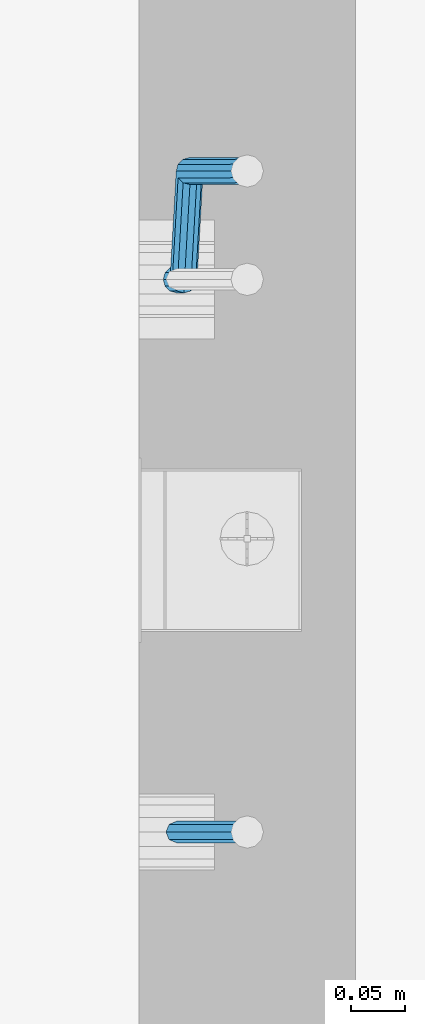
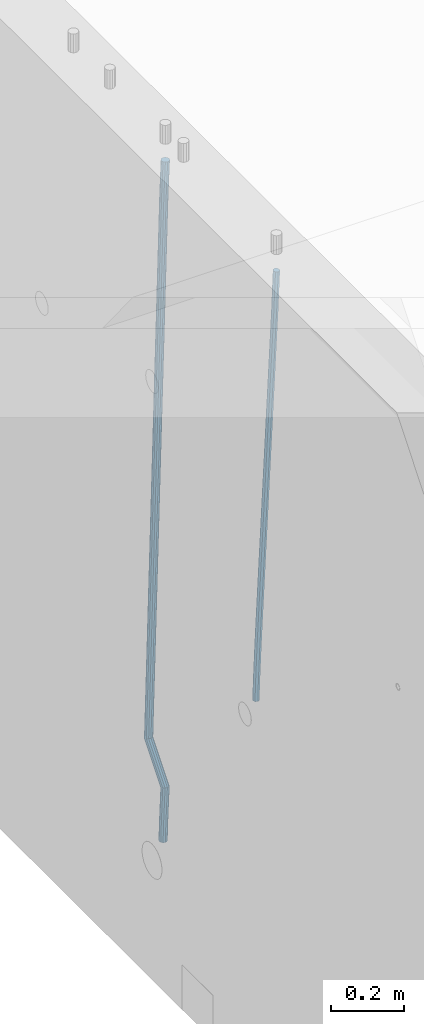
# One storey, part 103 of 349: 2 beams, 1 element without a shape of its own.
"""IFC2X3 building model written with IfcOpenShell, lengths in millimetres."""

from ifc_helpers import new_model, si_unit, frame, origin_with_axes, place, context, subcontext, project, spatial, faceted_brep, material, type_object, element, aggregate, save


model = new_model("IFC2X3")

# Units and contexts
model_context = context("Model", 3, precision=1e-05, world=origin_with_axes())
body_context = subcontext(model_context, "Body", "Model", "MODEL_VIEW")
ifc_project = project(units=[si_unit("LENGTHUNIT", "METRE", prefix="MILLI"), si_unit("AREAUNIT", "SQUARE_METRE"), si_unit("VOLUMEUNIT", "CUBIC_METRE"), si_unit("MASSUNIT", "GRAM", prefix="KILO"), si_unit("TIMEUNIT", "SECOND"), si_unit("PLANEANGLEUNIT", "RADIAN"), si_unit("SOLIDANGLEUNIT", "STERADIAN"), si_unit("THERMODYNAMICTEMPERATUREUNIT", "DEGREE_CELSIUS"), si_unit("LUMINOUSINTENSITYUNIT", "LUMEN")], contexts=[model_context])

# Site, building, storey
site_placement = place(None, origin_with_axes())
site = spatial("IfcSite", under=ifc_project, at=site_placement, CompositionType="ELEMENT")
building_placement = place(site_placement, origin_with_axes())
building = spatial("IfcBuilding", under=site, at=building_placement, CompositionType="ELEMENT")
storey_placement = place(building_placement, origin_with_axes())
storey = spatial("IfcBuildingStorey", under=building, at=storey_placement, Name="4", CompositionType="ELEMENT", Elevation=0.0)

# Assembly, beams
assembly_placement = place(storey_placement, origin_with_axes())
assembly = element("IfcElementAssembly", 1, at=assembly_placement, inside=storey, AssemblyPlace="NOTDEFINED", PredefinedType="REINFORCEMENT_UNIT")
ifc_material = material()
beam_type_1 = type_object("IfcBeamType", Name="D20", PredefinedType="NOTDEFINED")
beam_1_placement = place(assembly_placement, frame((21744.9999977209, 9994.99999999607, 91990.0), z_axis=(0.999642804629538, 0.000205762999925497, -0.0267249099901003), x_axis=(0.0267249109941254, -4.30000210532798e-08, 0.999642825779465)))
beam_1 = element("IfcBeam", 2, at=beam_1_placement, type_object=beam_type_1, material=ifc_material, Name="JM20", ObjectType="D20", context=body_context, shape_type="Brep", body=[
    faceted_brep([(0.0, -10.0, 0.0), (-4.19531716033816e-08, -7.07106781186667, -7.07106781187031), (60.4266690400545, -7.0710677960451, -7.07106780570757), (60.4266690441291, -9.99999998418934, 6.15546014159918e-09), (0.0, 0.0, -10.0), (60.426669036824, 1.58106558956206e-08, -9.99999999384454), (4.196772351861e-08, 7.07106781186303, -7.07106781186667), (60.4266690363438, 7.07106782768096, -7.07106780570757), (0.0, 10.0, 0.0), (60.4266690388904, 10.0000000158179, 6.15182216279209e-09), (4.196772351861e-08, 7.07106781185939, 7.07106781185939), (60.4266690429649, 7.07106782768096, 7.07106781802577), (0.0, 0.0, 10.0), (60.4266690461809, 1.58179318532348e-08, 10.0000000061555), (-4.19531716033816e-08, -7.07106781187031, 7.07106781185939), (60.4266690466611, -7.07106779605238, 7.07106781802213), (61.0378400410118, -7.07106779588503, -7.07106780564936), (60.991799419251, -9.99999998403655, 6.21366780251265e-09), (61.0569027789461, 1.5985278878361e-08, -9.99999999378269), (61.0378209396877, 7.07106782784831, -7.07106780564936), (60.9917724058905, 10.0000000159635, 6.21366780251265e-09), (60.9457317841297, 7.07106782781193, 7.0710678180767), (60.9266690461809, 1.59488990902901e-08, 10.0000000062028), (60.9457508854539, -7.07106779591413, 7.0710678180767), (61.6489592143771, -7.07106614513759, -7.06310863441468), (61.5568818710308, -9.9999984576425, 0.00735959856683621), (61.6870830769039, 1.71821739058942e-06, -9.99179257185824), (61.6489210170112, 7.07106947854481, -7.06310888312146), (61.556827851804, 10.0000015422847, 0.00735924683976918), (61.4647505084577, 7.07106922979438, 7.07782747982128), (61.4266266459163, 1.36643211590126e-06, 10.0065114172685), (61.464788705809, -7.07106639389531, 7.07782772852806), (176.543135720174, -7.07075579406956, -5.56673531796696), (176.451058376813, -9.99968810657447, 1.50373291501455), (176.581259582701, 0.000312069292704109, -8.49541925541052), (176.543097522794, 7.07137982961285, -5.56673556667374), (176.451004357587, 10.00031189336, 1.50373256329476), (176.35892701424, 7.07137958085514, 8.57420079627263), (176.320803151699, 0.000311717507429421, 11.5028847337162), (176.358965211621, -7.07075604281999, 8.57420104497578), (177.098753836006, -7.07075429323595, -5.55949898843028), (176.98362511232, -9.99968666800123, 1.510669025065), (177.146421932586, 0.000313595905026887, -8.48805862247536), (177.098706077581, 7.07138133041735, -5.55949936166144), (176.983557571715, 10.0003133318824, 1.51066849724157), (176.868428848029, 7.07138095712435, 8.58083651073321), (176.820760751449, 0.000313067976094317, 11.5093961447819), (176.868476606425, -7.07075466652896, 8.58083688396073), (177.654312950661, -7.07075204110879, -5.54863964998367), (177.516135294456, -9.99968450931192, 1.52107783331303), (177.711524267797, 0.000315886711177882, -8.47701274570863), (177.654255632195, 7.07138358250813, -5.54864021007961), (177.516054233929, 10.0003154905207, 1.5210770412159), (177.377876577739, 7.0713830223176, 8.59079452451624), (177.320665260588, 0.000315094497636892, 11.5191676202448), (177.377933896176, -7.07075260129932, 8.59079508461218), (299.599458226279, -7.07025770011387, -3.16501643125957), (299.461280570089, -9.99919016831518, 3.90470105203713), (299.65666954343, 0.000810227711554035, -6.09338952698454), (299.599400907857, 7.07187792350123, -3.16501699135551), (299.461199509577, 10.0008098315193, 3.90470025994), (299.323021853372, 7.07187736331798, 10.9744177432367), (299.265810536235, 0.000809435492556077, 13.9027908389617), (299.323079171809, -7.07025826029712, 10.9744183033363), (300.117505425049, -7.07025560005422, -3.15489032637561), (299.971788958996, -9.99918809853989, 3.91467979818117), (300.177827776904, 0.000812340382253751, -6.0832026116841), (300.117445104319, 7.07188002354815, -3.15489094515215), (299.971753863239, 10.0008119014747, 3.91467990454839), (299.826037397244, 7.07187940244148, 10.9842500291161), (299.765715045374, 0.000811462005003705, 13.9125623144282), (299.826097717974, -7.07025622116089, 10.9842506478926), (300.635529927473, -7.07025328000054, -3.14366299205358), (300.482325191449, -9.99918581231213, 3.92574478310053), (300.69896317774, 0.000814674367575208, -6.07190785373314), (300.635466604566, 7.07188234358546, -3.14366367590264), (300.482235639342, 10.000814187486, 3.92574381599843), (300.329030903304, 7.07188165517618, 10.9951515911598), (300.265597653051, 0.000813700806247653, 13.9233964528321), (300.329094226225, -7.07025396841345, 10.9951522750052), (1294.72134140272, -7.06580111335825, 18.4015220180045), (1294.5681366667, -9.99473364566802, 25.4709297931586), (1294.78477465297, 0.00526684101168939, 15.4732771563286), (1294.7212780798, 7.07633451023139, 18.4015213341554), (1294.56804711456, 10.0052663541301, 25.4709288260528), (1294.41484237854, 7.07633382181848, 32.5403366012142), (1294.35140912827, 0.00526586744854285, 35.4685814628901), (1294.41490570146, -7.06580180177116, 32.5403372850597), (1295.22122401037, -7.065798874557, 18.4123561564047), (1295.07847764336, -9.99473136002962, 25.4819905996155), (1295.31851894651, 0.00526923146571789, 15.4848451914186), (1295.31336839774, 7.07633716199962, 18.4143539239521), (1295.20878948565, 10.005269223795, 25.4848158695786), (1295.06604311864, 7.07633673832242, 32.5544503127894), (1294.96874818249, 0.00526863229970331, 35.4819612777756), (1294.97389873129, -7.0657992982342, 32.5524525452383), (1295.72113723878, -7.07231784537726, 18.4190095076701), (1295.5888498814, -10.0013867184771, 25.4887831499691), (1295.85229593501, -0.00169132971677755, 15.4919492358822), (1295.90549498468, 7.06861571010995, 18.4222345439302), (1295.84957110598, 9.99691330030873, 25.4933440399909), (1295.71728374861, 7.06784442721073, 32.5631176822862), (1295.58612505237, -0.00278208844792971, 35.4901779540742), (1295.53292600272, -7.07308912827466, 32.5598926460261), (1317.55191410908, -7.35699564410061, 18.7095555837295), (1317.41962675171, -10.2860645171968, 25.7793292260321), (1317.68307280532, -0.28636912843649, 15.7824953119416), (1317.73627185497, 6.7839379113866, 18.7127806199969), (1317.68034797629, 9.71223550158902, 25.783890116054), (1317.54806061891, 6.7831666284892, 32.8536637583529), (1317.41690192268, -0.2874598871731, 35.7807240301408), (1317.363702873, -7.35776692699619, 32.8504387220928), (1318.18734857353, -7.36528183957671, 18.7180125887826), (1318.07971594617, -10.2946722153993, 25.7881143611849), (1318.26138049197, -0.293910379039517, 15.7901920160075), (1318.25844480767, 6.77712866920592, 18.7197302261993), (1318.18026120469, 9.70571653076877, 25.7905434673194), (1318.07262857731, 6.7763261549444, 32.8606452397216), (1317.99859665887, -0.295045305590975, 35.7884658124931), (1318.00153234317, -7.36608435383823, 32.8589276023013), (1318.82283685768, -7.36340599946743, 18.7262747478708), (1318.73986089561, -10.2927036625733, 25.7967042930031), (1318.83973741514, -0.292212851787554, 15.7976939308101), (1318.78066245062, 6.77866673671087, 18.7264847659571), (1318.68021727716, 9.70720740099387, 25.7970013034283), (1318.59724131509, 6.77790973788615, 32.867430848557), (1318.58034075763, -0.293283409790092, 35.7960116656141), (1318.63941572215, -7.36416299828852, 32.8672208304743), (1418.8436227144, -7.06514386045455, 20.0236527734232), (1418.76064675233, -9.99444152356227, 27.0940823185556), (1418.86052327185, 0.00604928722168552, 17.0950719563662), (1418.80144830733, 7.07692887572193, 20.0238627915096), (1418.70100313389, 10.0054695400049, 27.0943793289771), (1418.61802717182, 7.07617187689721, 34.1648088741131), (1418.60112661435, 0.00497872922096576, 37.0933896911702), (1418.66020157887, -7.06590085927746, 34.1645988560231)], [[[0, 1, 2, 3]], [[1, 4, 5, 2]], [[4, 6, 7, 5]], [[6, 8, 9, 7]], [[8, 10, 11, 9]], [[10, 12, 13, 11]], [[12, 14, 15, 13]], [[14, 0, 3, 15]], [[14, 12, 10, 8, 6, 4, 1, 0]], [[3, 2, 16, 17]], [[2, 5, 18, 16]], [[5, 7, 19, 18]], [[7, 9, 20, 19]], [[9, 11, 21, 20]], [[11, 13, 22, 21]], [[13, 15, 23, 22]], [[15, 3, 17, 23]], [[17, 16, 24, 25]], [[16, 18, 26, 24]], [[18, 19, 27, 26]], [[19, 20, 28, 27]], [[20, 21, 29, 28]], [[21, 22, 30, 29]], [[22, 23, 31, 30]], [[23, 17, 25, 31]], [[25, 24, 32, 33]], [[24, 26, 34, 32]], [[26, 27, 35, 34]], [[27, 28, 36, 35]], [[28, 29, 37, 36]], [[29, 30, 38, 37]], [[30, 31, 39, 38]], [[31, 25, 33, 39]], [[33, 32, 40, 41]], [[32, 34, 42, 40]], [[34, 35, 43, 42]], [[35, 36, 44, 43]], [[36, 37, 45, 44]], [[37, 38, 46, 45]], [[38, 39, 47, 46]], [[39, 33, 41, 47]], [[41, 40, 48, 49]], [[40, 42, 50, 48]], [[42, 43, 51, 50]], [[43, 44, 52, 51]], [[44, 45, 53, 52]], [[45, 46, 54, 53]], [[46, 47, 55, 54]], [[47, 41, 49, 55]], [[49, 48, 56, 57]], [[48, 50, 58, 56]], [[50, 51, 59, 58]], [[51, 52, 60, 59]], [[52, 53, 61, 60]], [[53, 54, 62, 61]], [[54, 55, 63, 62]], [[55, 49, 57, 63]], [[57, 56, 64, 65]], [[56, 58, 66, 64]], [[58, 59, 67, 66]], [[59, 60, 68, 67]], [[60, 61, 69, 68]], [[61, 62, 70, 69]], [[62, 63, 71, 70]], [[63, 57, 65, 71]], [[65, 64, 72, 73]], [[64, 66, 74, 72]], [[66, 67, 75, 74]], [[67, 68, 76, 75]], [[68, 69, 77, 76]], [[69, 70, 78, 77]], [[70, 71, 79, 78]], [[71, 65, 73, 79]], [[73, 72, 80, 81]], [[72, 74, 82, 80]], [[74, 75, 83, 82]], [[75, 76, 84, 83]], [[76, 77, 85, 84]], [[77, 78, 86, 85]], [[78, 79, 87, 86]], [[79, 73, 81, 87]], [[81, 80, 88, 89]], [[80, 82, 90, 88]], [[82, 83, 91, 90]], [[83, 84, 92, 91]], [[84, 85, 93, 92]], [[85, 86, 94, 93]], [[86, 87, 95, 94]], [[87, 81, 89, 95]], [[89, 88, 96, 97]], [[88, 90, 98, 96]], [[90, 91, 99, 98]], [[91, 92, 100, 99]], [[92, 93, 101, 100]], [[93, 94, 102, 101]], [[94, 95, 103, 102]], [[95, 89, 97, 103]], [[97, 96, 104, 105]], [[96, 98, 106, 104]], [[98, 99, 107, 106]], [[99, 100, 108, 107]], [[100, 101, 109, 108]], [[101, 102, 110, 109]], [[102, 103, 111, 110]], [[103, 97, 105, 111]], [[105, 104, 112, 113]], [[104, 106, 114, 112]], [[106, 107, 115, 114]], [[107, 108, 116, 115]], [[108, 109, 117, 116]], [[109, 110, 118, 117]], [[110, 111, 119, 118]], [[111, 105, 113, 119]], [[113, 112, 120, 121]], [[112, 114, 122, 120]], [[114, 115, 123, 122]], [[115, 116, 124, 123]], [[116, 117, 125, 124]], [[117, 118, 126, 125]], [[118, 119, 127, 126]], [[119, 113, 121, 127]], [[121, 120, 128, 129]], [[120, 122, 130, 128]], [[122, 123, 131, 130]], [[123, 124, 132, 131]], [[124, 125, 133, 132]], [[125, 126, 134, 133]], [[126, 127, 135, 134]], [[127, 121, 129, 135]], [[130, 131, 132, 133, 134, 135, 129, 128]]]),
])
beam_type_2 = type_object("IfcBeamType", Name="D25", PredefinedType="NOTDEFINED")
beam_2_placement = place(assembly_placement, frame((21744.9999977209, 10504.9999999961, 91210.0), z_axis=(0.999642804629538, 0.000205762999925497, -0.0267249099901003), x_axis=(0.0267249109941254, -4.30000210532798e-08, 0.999642825779465)))
beam_2 = element("IfcBeam", 3, at=beam_2_placement, type_object=beam_type_2, material=ifc_material, Name="JM25", ObjectType="D25", context=body_context, shape_type="Brep", body=[
    faceted_brep([(-7.41420080885291e-08, -12.5, -3.63797880709171e-12), (-6.42030499875546e-08, -10.8253175473074, -6.25000000000364), (60.4103898235917, -10.8253175318459, -6.2499999938409), (60.4103898269532, -12.4999999845422, 6.16273609921336e-09), (-3.70782800018787e-08, -6.25000000000364, -10.8253175473074), (60.4103898202884, -6.24999998454587, -10.8253175411446), (-1.45519152283669e-11, -3.63797880709171e-12, -12.5), (60.4103898179019, 1.54577719513327e-08, -12.4999999938373), (3.70637280866504e-08, 6.25, -10.8253175473074), (60.410389817087, 6.25000001545777, -10.825317541141), (6.42030499875546e-08, 10.8253175473001, -6.25000000000364), (60.410389818062, 10.8253175627578, -6.24999999383726), (7.41420080885291e-08, 12.4999999999927, 0.0), (60.4103898205503, 12.5000000154541, 6.16273609921336e-09), (6.42176019027829e-08, 10.8253175473001, 6.24999999999636), (60.4103898238973, 10.8253175627651, 6.2500000061591), (3.70928319171071e-08, 6.24999999999636, 10.8253175473037), (60.4103898272151, 6.25000001546141, 10.8253175534664), (1.45519152283669e-11, -3.63797880709171e-12, 12.4999999999964), (60.4103898296162, 1.54541339725256e-08, 12.5000000061591), (-3.7049176171422e-08, -6.25000000000364, 10.8253175473001), (60.4103898304165, -6.24999998454587, 10.8253175534701), (-6.41884980723262e-08, -10.8253175473074, 6.25), (60.4103898294561, -10.8253175318459, 6.25000000616637), (61.0324985728803, -10.8253175316895, -6.24999999377542), (60.991802792938, -12.4999999843931, 6.22458173893392e-09), (61.0622854283865, -6.24999998437852, -10.8253175410755), (61.0731819955545, 1.5628756955266e-08, -12.4999999937718), (61.0622685480339, 6.25000001562512, -10.8253175410791), (61.032469335245, 10.8253175629216, -6.24999999377178), (60.9917690322181, 12.5000000156033, 6.22458173893392e-09), (60.9510732522613, 10.8253175629034, 6.25000000621731), (60.9212863967696, 6.25000001558874, 10.8253175535247), (60.9103898296162, 1.55814632307738e-08, 12.5000000062137), (60.9213032771368, -6.24999998441126, 10.8253175535174), (60.9511024898966, -10.8253175317113, 6.25000000621731), (61.6545545670233, -10.8253158516927, -6.24189838219536), (61.573166454793, -12.499998414296, 0.00757164385504439), (61.7141257553885, -6.24999822394238, -10.8168280205282), (61.7359179680789, 1.80548886419274e-06, -12.491368569139), (61.7140919992817, 6.25000177601396, -10.8168282403167), (61.6544960997562, 10.8253192428383, -6.2418987628771), (61.5730989426083, 12.5000015856094, 0.0075712042817031), (61.4917108303925, 10.8253190230062, 6.25704123032847), (61.4321396420273, 6.25000139525582, 10.8319708686649), (61.4103474293224, 1.36582457344048e-06, 12.5065114172721), (61.4321733981196, -6.24999860470052, 10.8319710884571), (61.4917692976451, -10.8253160715249, 6.25704161101385), (171.496768358847, -10.8250191983461, -4.81132145704032), (171.415380246617, -12.4997017609512, 1.43814856900644), (171.556339547184, -6.24970157059397, -9.38625109538043), (171.578131759845, 0.000298458835459314, -11.0607916439913), (171.556305791062, 6.25029842936056, -9.38625131517256), (171.496709891493, 10.8256158961849, -4.8113218377257), (171.415312734331, 12.5002982389578, 1.43814812942583), (171.333924622115, 10.8256156763564, 7.68761815547623), (171.274353433779, 6.2502980486006, 12.2625477938163), (171.252561221118, 0.000298019174806541, 13.9370883424199), (171.274387189915, -6.24970195135211, 12.2625480136048), (171.333983089469, -10.8250194181783, 7.68761853615797), (172.716738696545, -10.8250159035488, -4.79543265296888), (171.915337846367, -12.4997004107063, 1.4446599800649), (174.661439267307, -6.24969318458898, -9.34581050468478), (177.228358611188, 0.000313718517645611, -10.9872035044536), (179.729692762965, 6.25032050338996, -9.27980172353637), (181.495211256653, 10.8256428993391, -4.681102090286), (182.051844837653, 12.5003269652552, 1.57667754235081), (181.250443987461, 10.8256424580995, 7.81677017537731), (179.305743416699, 6.25031973913974, 12.3671480270932), (176.738824072818, 0.000312836033117492, 14.0085410268657), (174.237489921055, -6.24969394883919, 12.3011392459521), (172.471971427352, -10.8250163447901, 7.70243961269443), (173.591912530683, -11.6747326915593, -4.77028868389971), (172.273993951298, -12.8479239311091, 1.45496426209138), (176.888954103924, -8.41241409598842, -9.2818134312256), (181.281679044056, -3.93510377752864, -10.8707505672064), (185.593060250772, 0.557506579716573, -9.1113456694402), (188.667866611489, 3.86162565862105, -4.4750298594372), (189.682206244979, 5.09191742029725, 1.79589978565855), (188.364287665579, 3.91872618074558, 8.021152731646), (185.067246092338, 0.656407585174748, 12.5326774789683), (180.674521152207, -3.8209027332814, 14.1216146149563), (176.36313994549, -8.31351309053025, 12.3622097171901), (173.288333584787, -11.6176321694347, 7.72589390718713), (268.598404954697, -103.917677387682, -2.04072775141685), (267.280486375297, -105.090868627234, 4.18452519456696), (271.895446527924, -100.65535879211, -6.55225249874275), (276.288171468055, -96.1780484736537, -8.1411896347272), (280.599552674787, -91.6854381164067, -6.38178473695734), (283.674359035489, -88.3813190374985, -1.74546892695435), (284.688698668993, -87.1510272758242, 4.52546071813777), (283.370780089594, -88.324218515374, 10.7507136641289), (280.073738516352, -91.5865371109467, 15.2622384114547), (275.681013576221, -96.0638474294028, 16.8511755474319), (271.369632369504, -100.55645778665, 15.0917706496657), (268.294826008787, -103.860576865558, 10.4554548396627), (275.678171584295, -110.79150784929, -1.83732423750553), (274.910466417045, -112.498907899753, 4.40373648114473), (277.598256296449, -106.192285297533, -6.38840930916194), (280.156235405506, -99.933598213036, -8.0300591641826), (282.666700474903, -93.69245674577, -6.32239504965401), (284.456974416695, -89.1411697117383, -1.72298418601713), (285.047354773909, -87.4992507962288, 4.53576500016788), (284.279649606659, -89.2066508466924, 10.7768257188254), (282.359564894505, -93.805873398449, 15.3279107904782), (279.801585785448, -100.064560482946, 16.9695606454916), (277.291120716036, -106.30570195021, 15.2618965309666), (275.500846774259, -110.856988984244, 10.6624856673297), (285.548025314434, -110.791507724489, -1.83628607281935), (285.547368862506, -112.498907765255, 4.40485532817547), (285.548503982704, -106.192285197007, -6.38757305904073), (285.548676608552, -99.933598144853, -8.02949195800102), (285.548496937015, -93.6924567093301, -6.32209192668597), (285.548013110951, -89.1411696979412, -1.72286942465507), (285.547354771159, -87.499250789906, 4.53581759287408), (285.546698319231, -89.2066508306707, 10.7769589938689), (285.546219650962, -93.8058733581547, 15.3282459800866), (285.546047025127, -100.06456041031, 16.9701648790469), (285.54622669665, -106.305701845829, 15.2627648477392), (285.546710522714, -110.856988857218, 10.6635423457046), (2074.25333672202, -110.791485106987, -1.64814035737072), (2074.2526802701, -112.498885147752, 4.59300104362046), (2074.25381539032, -106.192262579505, -6.19942734358847), (2074.25398801616, -99.9335755273514, -7.84134624254875), (2074.25380834464, -93.6924340918322, -6.13394621124462), (2074.25332451856, -89.1411470804433, -1.53472370920645), (2074.25266617877, -87.499228172408, 4.72396330832635), (2074.25200972684, -89.2066282131709, 10.9651047093175), (2074.25153105859, -93.8058507406568, 15.5163916955389), (2074.25135843272, -100.06453779281, 17.1583105944992), (2074.25153810425, -106.305679228328, 15.4509105631842), (2074.25202193031, -110.856966239717, 10.8516880611533), (2074.83696830293, -110.791485099611, -1.64807896783896), (2074.78398067175, -112.498885141034, 4.59305692867565), (2074.89747594834, -106.192262571365, -6.1993596398861), (2074.94929063322, -99.9335755185584, -7.84127310686017), (2074.97852865464, -93.6924340826681, -6.13386998122951), (2074.97735570835, -89.1411470712865, -1.5346475516817), (2074.94608608437, -87.4992281636405, 4.72403624598519), (2074.89309845318, -89.2066282050637, 10.9651721425071), (2074.8325908078, -93.8058507333099, 15.5164528145506), (2074.78077612289, -100.064537786115, 17.158366281521), (2074.75153810147, -106.305679222007, 15.4509631558976), (2074.75271104777, -110.856966233388, 10.8517407263462), (2075.42049860313, -110.799094351876, -1.64031275624438), (2075.315188874, -112.505812111609, 4.60012678485873), (2075.5410248085, -106.200654467422, -6.19079464056631), (2075.64447259072, -99.9426407117207, -7.8320209220401), (2075.70312320006, -93.7018828168402, -6.1242263439417), (2075.70126125314, -89.1505868208715, -1.52501308430874), (2075.63938565711, -87.5082688104485, 4.73326337811886), (2075.53407592798, -89.2149865701776, 10.9737029192256), (2075.41354972261, -93.8134264546352, 15.5241848035512), (2075.31010194038, -100.071440210337, 17.1654110850213), (2075.25145133105, -106.312198105215, 15.4576165069193), (2075.25331327796, -110.863494101184, 10.85840324729), (2097.1945896636, -111.08302913941, -1.35052112331687), (2097.08927993447, -112.789746899141, 4.88991841778625), (2097.31511586897, -106.484589254955, -5.90100300764971), (2097.41856365118, -100.226575499253, -7.54222928911986), (2097.47721426054, -93.9858176043745, -5.83443471101782), (2097.4753523136, -89.4345216084039, -1.23522145138486), (2097.41347671759, -87.7922035979809, 5.02305501104274), (2097.30816698846, -89.4989213577119, 11.2634945521422), (2097.18764078306, -94.0973612421694, 15.8139764364751), (2097.08419300086, -100.355374997869, 17.4552027179489), (2097.02554239152, -106.596132892748, 15.7474081398468), (2097.02740433844, -111.147428888718, 11.1481948802139), (2097.87997251838, -111.091966551987, -1.34139935488201), (2097.78938683082, -112.798876313653, 4.89923614866711), (2097.96289911156, -106.493036367479, -5.89238165288771), (2098.01594649666, -100.234365389122, -7.5342787138361), (2098.02490066971, -93.9929594512505, -5.82714554618724), (2097.98736236728, -89.4411982345555, -1.22840710358651), (2097.91338994715, -87.7987224811914, 5.02970836206805), (2097.82280425957, -89.5056322428572, 11.2703438656135), (2097.7398776664, -94.1045624273629, 15.8213261636229), (2097.68683028129, -100.363233405722, 17.4632232245676), (2097.67787610824, -106.604639343592, 15.7560900569224), (2097.71541441069, -111.156400560287, 11.1573516143217), (2098.56541322041, -111.089943792393, -1.33247210230547), (2098.48955268873, -112.796788628493, 4.90836015004606), (2098.61073725206, -106.491141065437, -5.88395763208973), (2098.61338024602, -100.23262592446, -7.5265295672325), (2098.57263401416, -93.9913624473083, -5.82006208420717), (2098.49941647641, -89.4396921424323, -1.22180176699476), (2098.4133462129, -87.7972313922346, 5.03615124581847), (2098.33748568122, -89.5040762283334, 11.2769834981773), (2098.29216164956, -94.1028789552893, 15.8284690279543), (2098.28951865561, -100.361394096264, 17.4710409631007), (2098.33026488747, -106.602657573418, 15.7645734800717), (2098.4034824252, -111.154327878296, 11.1663131628593), (2198.56618852627, -110.791740651814, -0.0353536246875592), (2198.49032799456, -112.498585487912, 6.20547862766762), (2198.61151255792, -106.19293792486, -4.58683915447182), (2198.61415555187, -99.9344227838828, -6.22941108961459), (2198.57340932002, -93.6931593067293, -4.52294360658198), (2198.50019178227, -89.1414890018532, 0.0753167106267938), (2198.41412151874, -87.4990282516574, 6.33326972344003), (2198.33826098708, -89.2058730877579, 12.5741019757952), (2198.29293695542, -93.8046758147102, 17.1255875055758), (2198.29029396146, -100.063190955687, 18.768159440715), (2198.33104019333, -106.30445443284, 17.0616919576896), (2198.40425773106, -110.856124737718, 12.4634316404808)], [[[0, 1, 2, 3]], [[1, 4, 5, 2]], [[4, 6, 7, 5]], [[6, 8, 9, 7]], [[8, 10, 11, 9]], [[10, 12, 13, 11]], [[12, 14, 15, 13]], [[14, 16, 17, 15]], [[16, 18, 19, 17]], [[18, 20, 21, 19]], [[20, 22, 23, 21]], [[22, 0, 3, 23]], [[22, 20, 18, 16, 14, 12, 10, 8, 6, 4, 1, 0]], [[3, 2, 24, 25]], [[2, 5, 26, 24]], [[5, 7, 27, 26]], [[7, 9, 28, 27]], [[9, 11, 29, 28]], [[11, 13, 30, 29]], [[13, 15, 31, 30]], [[15, 17, 32, 31]], [[17, 19, 33, 32]], [[19, 21, 34, 33]], [[21, 23, 35, 34]], [[23, 3, 25, 35]], [[25, 24, 36, 37]], [[24, 26, 38, 36]], [[26, 27, 39, 38]], [[27, 28, 40, 39]], [[28, 29, 41, 40]], [[29, 30, 42, 41]], [[30, 31, 43, 42]], [[31, 32, 44, 43]], [[32, 33, 45, 44]], [[33, 34, 46, 45]], [[34, 35, 47, 46]], [[35, 25, 37, 47]], [[37, 36, 48, 49]], [[36, 38, 50, 48]], [[38, 39, 51, 50]], [[39, 40, 52, 51]], [[40, 41, 53, 52]], [[41, 42, 54, 53]], [[42, 43, 55, 54]], [[43, 44, 56, 55]], [[44, 45, 57, 56]], [[45, 46, 58, 57]], [[46, 47, 59, 58]], [[47, 37, 49, 59]], [[49, 48, 60, 61]], [[48, 50, 62, 60]], [[50, 51, 63, 62]], [[51, 52, 64, 63]], [[52, 53, 65, 64]], [[53, 54, 66, 65]], [[54, 55, 67, 66]], [[55, 56, 68, 67]], [[56, 57, 69, 68]], [[57, 58, 70, 69]], [[58, 59, 71, 70]], [[59, 49, 61, 71]], [[61, 60, 72, 73]], [[60, 62, 74, 72]], [[62, 63, 75, 74]], [[63, 64, 76, 75]], [[64, 65, 77, 76]], [[65, 66, 78, 77]], [[66, 67, 79, 78]], [[67, 68, 80, 79]], [[68, 69, 81, 80]], [[69, 70, 82, 81]], [[70, 71, 83, 82]], [[71, 61, 73, 83]], [[73, 72, 84, 85]], [[72, 74, 86, 84]], [[74, 75, 87, 86]], [[75, 76, 88, 87]], [[76, 77, 89, 88]], [[77, 78, 90, 89]], [[78, 79, 91, 90]], [[79, 80, 92, 91]], [[80, 81, 93, 92]], [[81, 82, 94, 93]], [[82, 83, 95, 94]], [[83, 73, 85, 95]], [[85, 84, 96, 97]], [[84, 86, 98, 96]], [[86, 87, 99, 98]], [[87, 88, 100, 99]], [[88, 89, 101, 100]], [[89, 90, 102, 101]], [[90, 91, 103, 102]], [[91, 92, 104, 103]], [[92, 93, 105, 104]], [[93, 94, 106, 105]], [[94, 95, 107, 106]], [[95, 85, 97, 107]], [[97, 96, 108, 109]], [[96, 98, 110, 108]], [[98, 99, 111, 110]], [[99, 100, 112, 111]], [[100, 101, 113, 112]], [[101, 102, 114, 113]], [[102, 103, 115, 114]], [[103, 104, 116, 115]], [[104, 105, 117, 116]], [[105, 106, 118, 117]], [[106, 107, 119, 118]], [[107, 97, 109, 119]], [[109, 108, 120, 121]], [[108, 110, 122, 120]], [[110, 111, 123, 122]], [[111, 112, 124, 123]], [[112, 113, 125, 124]], [[113, 114, 126, 125]], [[114, 115, 127, 126]], [[115, 116, 128, 127]], [[116, 117, 129, 128]], [[117, 118, 130, 129]], [[118, 119, 131, 130]], [[119, 109, 121, 131]], [[121, 120, 132, 133]], [[120, 122, 134, 132]], [[122, 123, 135, 134]], [[123, 124, 136, 135]], [[124, 125, 137, 136]], [[125, 126, 138, 137]], [[126, 127, 139, 138]], [[127, 128, 140, 139]], [[128, 129, 141, 140]], [[129, 130, 142, 141]], [[130, 131, 143, 142]], [[131, 121, 133, 143]], [[133, 132, 144, 145]], [[132, 134, 146, 144]], [[134, 135, 147, 146]], [[135, 136, 148, 147]], [[136, 137, 149, 148]], [[137, 138, 150, 149]], [[138, 139, 151, 150]], [[139, 140, 152, 151]], [[140, 141, 153, 152]], [[141, 142, 154, 153]], [[142, 143, 155, 154]], [[143, 133, 145, 155]], [[145, 144, 156, 157]], [[144, 146, 158, 156]], [[146, 147, 159, 158]], [[147, 148, 160, 159]], [[148, 149, 161, 160]], [[149, 150, 162, 161]], [[150, 151, 163, 162]], [[151, 152, 164, 163]], [[152, 153, 165, 164]], [[153, 154, 166, 165]], [[154, 155, 167, 166]], [[155, 145, 157, 167]], [[157, 156, 168, 169]], [[156, 158, 170, 168]], [[158, 159, 171, 170]], [[159, 160, 172, 171]], [[160, 161, 173, 172]], [[161, 162, 174, 173]], [[162, 163, 175, 174]], [[163, 164, 176, 175]], [[164, 165, 177, 176]], [[165, 166, 178, 177]], [[166, 167, 179, 178]], [[167, 157, 169, 179]], [[169, 168, 180, 181]], [[168, 170, 182, 180]], [[170, 171, 183, 182]], [[171, 172, 184, 183]], [[172, 173, 185, 184]], [[173, 174, 186, 185]], [[174, 175, 187, 186]], [[175, 176, 188, 187]], [[176, 177, 189, 188]], [[177, 178, 190, 189]], [[178, 179, 191, 190]], [[179, 169, 181, 191]], [[181, 180, 192, 193]], [[180, 182, 194, 192]], [[182, 183, 195, 194]], [[183, 184, 196, 195]], [[184, 185, 197, 196]], [[185, 186, 198, 197]], [[186, 187, 199, 198]], [[187, 188, 200, 199]], [[188, 189, 201, 200]], [[189, 190, 202, 201]], [[190, 191, 203, 202]], [[191, 181, 193, 203]], [[194, 195, 196, 197, 198, 199, 200, 201, 202, 203, 193, 192]]]),
])
aggregate(assembly, [beam_2, beam_1])

save(model, "model.ifc")
